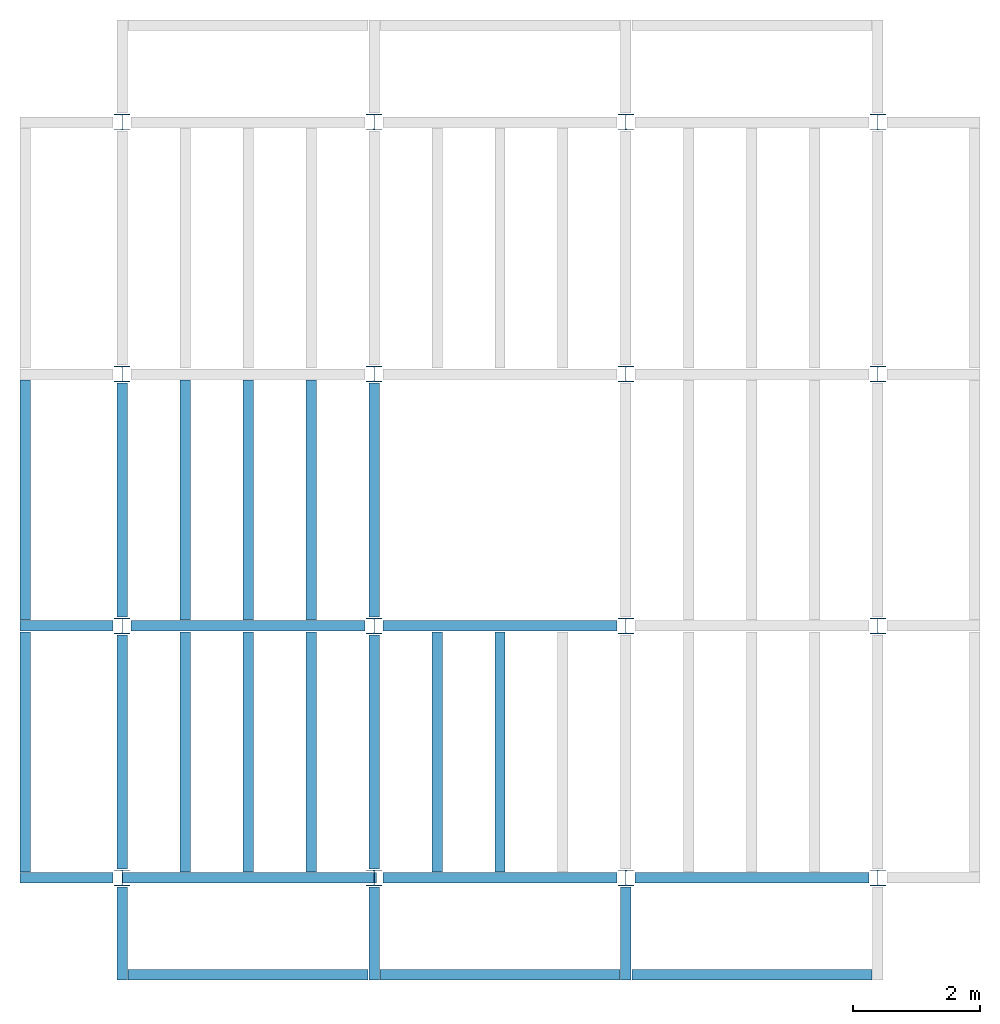
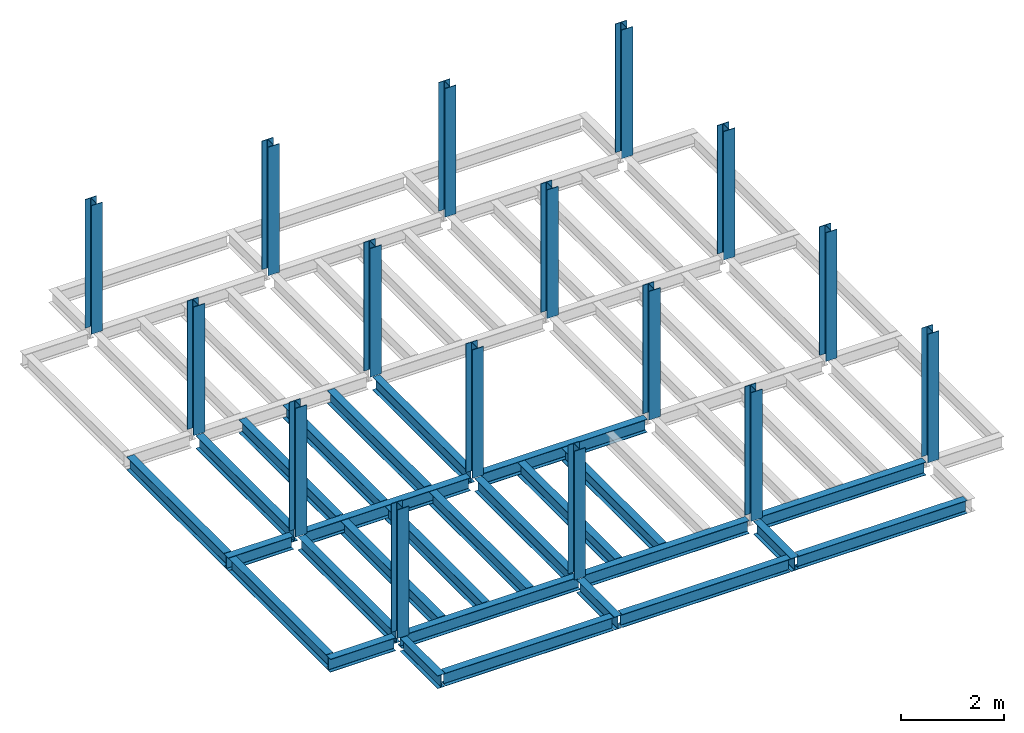
# One storey, part 1 of 3: 27 beams, 16 columns, 3 elements without a shape of their own.
"""IFC4 building model written with IfcOpenShell, lengths in feet."""

from ifc_helpers import new_model, entity, si_unit, converted_unit, derived_unit, direction, frame, origin, origin_2d, place, context, subcontext, project, spatial, line, arc, indexed_curve, i_section, outline, extrude, source, transform, mapped, material, type_object, type_shapes, element, aggregate, save


model = new_model("IFC4")

# Units and contexts
model_context = context("Model", 3, precision=0.0001, world=origin(), true_north=direction((6.123233995736766e-17, 1.0)))
plan_context = context("Plan", 3, precision=0.0001, world=origin(), true_north=direction((6.123233995736766e-17, 1.0)))
body_context = subcontext(model_context, "Body", "Model", "MODEL_VIEW")
ifc_project = project(units=[converted_unit("LENGTHUNIT", "FOOT", entity("IfcLengthMeasure", 0.3048), si_unit("LENGTHUNIT", "METRE"), dimensions=[1, 0, 0, 0, 0, 0, 0]), converted_unit("AREAUNIT", "SQUARE FOOT", entity("IfcAreaMeasure", 0.09290304), si_unit("AREAUNIT", "SQUARE_METRE"), dimensions=[2, 0, 0, 0, 0, 0, 0]), converted_unit("PLANEANGLEUNIT", "DEGREE", entity("IfcPlaneAngleMeasure", 0.017453292519943278), si_unit("PLANEANGLEUNIT", "RADIAN"), dimensions=[0, 0, 0, 0, 0, 0, 0]), converted_unit("VOLUMEUNIT", "CUBIC FOOT", entity("IfcVolumeMeasure", 0.028316846592000004), si_unit("VOLUMEUNIT", "CUBIC_METRE"), dimensions=[3, 0, 0, 0, 0, 0, 0]), si_unit("PRESSUREUNIT", "PASCAL"), derived_unit("MASSDENSITYUNIT", [(si_unit("MASSUNIT", "GRAM", prefix="KILO"), 1), (si_unit("LENGTHUNIT", "METRE"), -3)]), derived_unit("VAPORPERMEABILITYUNIT", [(si_unit("LENGTHUNIT", "METRE"), -1), (si_unit("TIMEUNIT", "SECOND"), 1)]), derived_unit("USERDEFINED", [(si_unit("MASSUNIT", "GRAM", prefix="KILO"), 1), (si_unit("LENGTHUNIT", "METRE"), 3), (si_unit("TIMEUNIT", "SECOND"), -3), (si_unit("ELECTRICCURRENTUNIT", "AMPERE"), -2)]), derived_unit("MODULUSOFELASTICITYUNIT", [(si_unit("MASSUNIT", "GRAM", prefix="KILO"), 1), (si_unit("LENGTHUNIT", "METRE"), -1), (si_unit("TIMEUNIT", "SECOND"), -2)]), derived_unit("THERMALEXPANSIONCOEFFICIENTUNIT", [(si_unit("THERMODYNAMICTEMPERATUREUNIT", "KELVIN"), -1)]), derived_unit("SPECIFICHEATCAPACITYUNIT", [(si_unit("TIMEUNIT", "SECOND"), -2), (si_unit("THERMODYNAMICTEMPERATUREUNIT", "KELVIN"), -1), (si_unit("LENGTHUNIT", "METRE"), 2)]), derived_unit("THERMALCONDUCTANCEUNIT", [(si_unit("MASSUNIT", "GRAM", prefix="KILO"), 1), (si_unit("TIMEUNIT", "SECOND"), -3), (si_unit("THERMODYNAMICTEMPERATUREUNIT", "KELVIN"), -1), (si_unit("LENGTHUNIT", "METRE"), 1)])], contexts=[model_context, plan_context])

# Site, building, storey
site_placement = place(None, origin())
site = spatial("IfcSite", under=ifc_project, at=site_placement, CompositionType="ELEMENT")
building_placement = place(site_placement, origin())
building = spatial("IfcBuilding", under=site, at=building_placement, CompositionType="ELEMENT")
storey_placement = place(building_placement, frame((0.0, 0.0, 59.875)))
storey = spatial("IfcBuildingStorey", under=building, at=storey_placement, Name="STR 07", CompositionType="ELEMENT", Elevation=59.875)

# Columns
ifc_material = material(Name="Steel ASTM A992", Category="Metal")
column_type = type_object("IfcColumnType", Name="W10X49", PredefinedType="COLUMN", material=ifc_material)
shared_shape_1 = source(origin(), body_context, "Body", "SweptSolid", [
    extrude(outline(indexed_curve([(-0.41666666666666663, -0.4166666666666676), (0.41666666666666663, -0.4166666666666676), (0.41666666666666663, -0.3699999999999996), (0.055833333333333846, -0.3699999999999996), (0.02637055078389421, -0.35779611588277277), (0.014166666666666636, -0.32833333333333287), (0.01416666666666665, 0.32833333333333303), (0.026370550783893467, 0.3577961158827727), (0.05583333333333332, 0.3700000000000003), (0.41666666666666663, 0.3700000000000003), (0.41666666666666663, 0.4166666666666656), (-0.41666666666666663, 0.4166666666666656), (-0.41666666666666663, 0.3700000000000003), (-0.05583333333333365, 0.3700000000000003), (-0.02637055078389416, 0.3577961158827734), (-0.014166666666666685, 0.32833333333333387), (-0.014166666666666685, -0.32833333333333264), (-0.026370550783893578, -0.3577961158827721), (-0.055833333333333374, -0.3699999999999996), (-0.41666666666666663, -0.3699999999999996)], segments=[line(1, 2, 3, 4), arc(4, 5, 6), line(6, 7), arc(7, 8, 9), line(9, 10, 11, 12, 13, 14), arc(14, 15, 16), line(16, 17), arc(17, 18, 19), line(19, 20, 1)], self_intersect=False)), frame((0.0, 0.0, 59.875), z_axis=(0.0, 0.0, 1.0), x_axis=(-1.0, 0.0, 0.0)), (0.0, 0.0, 1.0), 10.0),
])
type_shapes(column_type, [shared_shape_1])
for number, where, z_axis, x_axis, name in (
    (1, (0.0, 0.0, -59.875), (0.0, 0.0, 1.0), (-1.0, 0.0, 0.0), "W10X49"),
    (2, (0.0, 13.0, -59.875), (0.0, 0.0, 1.0), (-1.0, 0.0, 0.0), "W10X49"),
    (3, (0.0, 26.0, -59.875), (0.0, 0.0, 1.0), (-1.0, 0.0, 0.0), "W10X49"),
    (4, (0.0, 39.0, -59.875), (0.0, 0.0, 1.0), (-1.0, 0.0, 0.0), "W10X49"),
    (5, (13.0, 0.0, -59.875), (0.0, 0.0, 1.0), (-1.0, 0.0, 0.0), "W10X49"),
    (6, (13.0, 13.0, -59.875), (0.0, 0.0, 1.0), (-1.0, 0.0, 0.0), "W10X49"),
    (7, (13.0, 26.0, -59.875), (0.0, 0.0, 1.0), (-1.0, 0.0, 0.0), "W10X49"),
    (8, (13.0, 39.0, -59.875), (0.0, 0.0, 1.0), (-1.0, 0.0, 0.0), "W10X49"),
    (9, (26.0, 0.0, -59.875), (0.0, 0.0, 1.0), (-1.0, 0.0, 0.0), "W10X49"),
    (10, (26.0, 13.0, -59.875), (0.0, 0.0, 1.0), (-1.0, 0.0, 0.0), "W10X49"),
    (11, (26.0, 26.0, -59.875), (0.0, 0.0, 1.0), (-1.0, 0.0, 0.0), "W10X49"),
    (12, (26.0, 39.0, -59.875), (0.0, 0.0, 1.0), (-1.0, 0.0, 0.0), "W10X49"),
    (13, (39.0, 0.0, -59.875), (0.0, 0.0, 1.0), (-1.0, 0.0, 0.0), "W10X49"),
    (14, (39.0, 13.0, -59.875), (0.0, 0.0, 1.0), (-1.0, 0.0, 0.0), "W10X49"),
    (15, (39.0, 26.0, -59.875), (0.0, 0.0, 1.0), (-1.0, 0.0, 0.0), "W10X49"),
    (16, (39.0, 39.0, -59.875), (0.0, 0.0, 1.0), (-1.0, 0.0, 0.0), "W10X49"),
):
    element("IfcColumn", number, at=place(storey_placement, frame(where, z_axis=z_axis, x_axis=x_axis)), inside=storey, type_object=column_type, material=ifc_material, Name=name, ObjectType="W Shapes-Column:W10X49", PredefinedType="COLUMN", context=body_context, shape_type="MappedRepresentation", body=[
        mapped(shared_shape_1, transform((0.0, 0.0, 0.0), scale=1.0)),
    ])

# Beams
beam_type_1 = type_object("IfcBeamType", Name="W12X26", PredefinedType="JOIST", material=ifc_material)
shared_shape_2 = source(origin(), body_context, "Body", "SweptSolid", [
    extrude(outline(indexed_curve([(-0.27041666666666714, -0.47666666666666574), (-0.27041666666666714, -0.5083333333333351), (0.2704166666666669, -0.5083333333333351), (0.2704166666666669, -0.47666666666666574), (0.03458333333333309, -0.47666666666666574), (0.016905663803669493, -0.46934433619632937), (0.009583333333333202, -0.4516666666666659), (0.0095833333333332, 0.45166666666666705), (0.01690566380366948, 0.4693443361963307), (0.03458333333333325, 0.4766666666666671), (0.2704166666666669, 0.4766666666666671), (0.2704166666666669, 0.5083333333333312), (-0.2704166666666655, 0.5083333333333312), (-0.2704166666666655, 0.4766666666666671), (-0.034583333333333514, 0.47666666666666707), (-0.016905663803669865, 0.46934433619633054), (-0.009583333333333737, 0.45166666666666694), (-0.009583333333333735, -0.4516666666666658), (-0.01690566380367013, -0.4693443361963295), (-0.03458333333333368, -0.47666666666666574)], segments=[line(1, 2, 3, 4, 5), arc(5, 6, 7), line(7, 8), arc(8, 9, 10), line(10, 11, 12, 13, 14, 15), arc(15, 16, 17), line(17, 18), arc(18, 19, 20), line(20, 1)], self_intersect=False)), frame((-6.103346456692914, 0.0, 0.0), z_axis=(-1.0, 0.0, 0.0), x_axis=(0.0, -1.0, 0.0)), (0.0, 0.0, -1.0), 12.083333333333323),
])
type_shapes(beam_type_1, [shared_shape_2])
beam_1_placement = place(storey_placement, frame((6.561679790026266, 13.0, -0.5083333333333329)))
element("IfcBeam", 17, at=beam_1_placement, inside=storey, type_object=beam_type_1, material=ifc_material, Name="W12X26", ObjectType="W Shapes:W12X26", PredefinedType="JOIST", context=body_context, shape_type="MappedRepresentation", body=[
    mapped(shared_shape_2, transform((0.0, 0.0, 0.0), scale=1.0)),
])
for number, where, z_axis, x_axis, name in (
    (18, (0.0, 6.561679790026247, -0.5083333333333329), (0.0, 0.0, 1.0), (0.0, 1.0, 0.0), "W12X26"),
    (19, (13.0, 6.561679790026204, -0.5083333333333329), (0.0, 0.0, 1.0), (0.0, 1.0, 0.0), "W12X26"),
):
    element("IfcBeam", number, at=place(storey_placement, frame(where, z_axis=z_axis, x_axis=x_axis)), inside=storey, type_object=beam_type_1, material=ifc_material, Name=name, ObjectType="W Shapes:W12X26", PredefinedType="JOIST", context=body_context, shape_type="MappedRepresentation", body=[
        mapped(shared_shape_2, transform((0.0, 0.0, 0.0), scale=1.0)),
    ])
beam_type_2 = type_object("IfcBeamType", Name="W12X26", PredefinedType="JOIST", material=ifc_material)
shared_shape_3 = source(origin(), body_context, "Body", "SweptSolid", [
    extrude(outline(indexed_curve([(-0.27041666666666714, -0.47666666666666574), (-0.27041666666666714, -0.5083333333333351), (0.2704166666666669, -0.5083333333333351), (0.2704166666666669, -0.47666666666666574), (0.03458333333333309, -0.47666666666666574), (0.016905663803669493, -0.46934433619632937), (0.009583333333333202, -0.4516666666666659), (0.0095833333333332, 0.45166666666666705), (0.01690566380366948, 0.4693443361963307), (0.03458333333333325, 0.4766666666666671), (0.2704166666666669, 0.4766666666666671), (0.2704166666666669, 0.5083333333333312), (-0.2704166666666655, 0.5083333333333312), (-0.2704166666666655, 0.4766666666666671), (-0.034583333333333514, 0.47666666666666707), (-0.016905663803669865, 0.46934433619633054), (-0.009583333333333737, 0.45166666666666694), (-0.009583333333333735, -0.4516666666666658), (-0.01690566380367013, -0.4693443361963295), (-0.03458333333333368, -0.47666666666666574)], segments=[line(1, 2, 3, 4, 5), arc(5, 6, 7), line(7, 8), arc(8, 9, 10), line(10, 11, 12, 13, 14, 15), arc(15, 16, 17), line(17, 18), arc(18, 19, 20), line(20, 1)], self_intersect=False)), frame((-6.226706036745409, 0.0, 0.0), z_axis=(-1.0, 0.0, 0.0), x_axis=(0.0, -1.0, 0.0)), (0.0, 0.0, -1.0), 12.08333333333333),
])
type_shapes(beam_type_2, [shared_shape_3])
for number, where, name in (
    (20, (19.68503937007876, 13.0, -0.5083333333333329), "W12X26"),
    (21, (19.68503937007874, 0.0, -0.5083333333333329), "W12X26"),
):
    element("IfcBeam", number, at=place(storey_placement, frame(where)), inside=storey, type_object=beam_type_2, material=ifc_material, Name=name, ObjectType="W Shapes:W12X26", PredefinedType="JOIST", context=body_context, shape_type="MappedRepresentation", body=[
        mapped(shared_shape_3, transform((0.0, 0.0, 0.0), scale=1.0)),
    ])
for number, where, z_axis, x_axis, name in (
    (22, (0.0, 19.68503937007874, -0.5083333333333329), (0.0, 0.0, 1.0), (0.0, 1.0, 0.0), "W12X26"),
    (23, (13.0, 19.685039370078698, -0.5083333333333329), (0.0, 0.0, 1.0), (0.0, 1.0, 0.0), "W12X26"),
):
    element("IfcBeam", number, at=place(storey_placement, frame(where, z_axis=z_axis, x_axis=x_axis)), inside=storey, type_object=beam_type_2, material=ifc_material, Name=name, ObjectType="W Shapes:W12X26", PredefinedType="JOIST", context=body_context, shape_type="MappedRepresentation", body=[
        mapped(shared_shape_3, transform((0.0, 0.0, 0.0), scale=1.0)),
    ])

# Assembly, beams
assembly_1_placement = place(storey_placement, origin())
assembly_1 = element("IfcElementAssembly", 24, at=assembly_1_placement, inside=storey, Name="Structural Framing System", ObjectType="Structural Beam System:Structural Framing System", AssemblyPlace="NOTDEFINED", PredefinedType="BEAM_GRID")
beam_type_3 = type_object("IfcBeamType", Name="W12X26", PredefinedType="JOIST", material=ifc_material)
shared_shape_4 = source(origin(), body_context, "Body", "SweptSolid", [
    extrude(outline(indexed_curve([(-0.27041666666666714, -0.47666666666666574), (-0.27041666666666714, -0.5083333333333351), (0.2704166666666669, -0.5083333333333351), (0.2704166666666669, -0.47666666666666574), (0.03458333333333309, -0.47666666666666574), (0.016905663803669493, -0.46934433619632937), (0.009583333333333202, -0.4516666666666659), (0.0095833333333332, 0.45166666666666705), (0.01690566380366948, 0.4693443361963307), (0.03458333333333325, 0.4766666666666671), (0.2704166666666669, 0.4766666666666671), (0.2704166666666669, 0.5083333333333312), (-0.2704166666666655, 0.5083333333333312), (-0.2704166666666655, 0.4766666666666671), (-0.034583333333333514, 0.47666666666666707), (-0.016905663803669865, 0.46934433619633054), (-0.009583333333333737, 0.45166666666666694), (-0.009583333333333735, -0.4516666666666658), (-0.01690566380367013, -0.4693443361963295), (-0.03458333333333368, -0.47666666666666574)], segments=[line(1, 2, 3, 4, 5), arc(5, 6, 7), line(7, 8), arc(8, 9, 10), line(10, 11, 12, 13, 14, 15), arc(15, 16, 17), line(17, 18), arc(18, 19, 20), line(20, 1)], self_intersect=False)), frame((-6.187916666666566, 0.0, 0.0), z_axis=(-1.0, 0.0, 0.0), x_axis=(0.0, -1.0, 0.0)), (0.0, 0.0, -1.0), 12.375833333333075),
])
type_shapes(beam_type_3, [shared_shape_4])
beam_2_placement = place(assembly_1_placement, frame((3.250000000000031, 6.499999999999844, -0.5083333333333329), z_axis=(0.0, 0.0, 1.0), x_axis=(0.0, 1.0, 0.0)))
beam_2 = element("IfcBeam", 25, at=beam_2_placement, type_object=beam_type_3, material=ifc_material, Name="W12X26", ObjectType="W Shapes:W12X26", PredefinedType="JOIST", context=body_context, shape_type="MappedRepresentation", body=[
    mapped(shared_shape_4, transform((0.0, 0.0, 0.0), scale=1.0)),
])
beam_3_placement = place(assembly_1_placement, frame((6.5000000000000515, 6.4999999999998455, -0.5083333333333329), z_axis=(0.0, 0.0, 1.0), x_axis=(0.0, 1.0, 0.0)))
beam_3 = element("IfcBeam", 26, at=beam_3_placement, type_object=beam_type_3, material=ifc_material, Name="W12X26", ObjectType="W Shapes:W12X26", PredefinedType="JOIST", context=body_context, shape_type="MappedRepresentation", body=[
    mapped(shared_shape_4, transform((0.0, 0.0, 0.0), scale=1.0)),
])
beam_4_placement = place(assembly_1_placement, frame((9.750000000000073, 6.499999999999844, -0.5083333333333329), z_axis=(0.0, 0.0, 1.0), x_axis=(0.0, 1.0, 0.0)))
beam_4 = element("IfcBeam", 27, at=beam_4_placement, type_object=beam_type_3, material=ifc_material, Name="W12X26", ObjectType="W Shapes:W12X26", PredefinedType="JOIST", context=body_context, shape_type="MappedRepresentation", body=[
    mapped(shared_shape_4, transform((0.0, 0.0, 0.0), scale=1.0)),
])
aggregate(assembly_1, [beam_2, beam_3, beam_4])

assembly_2_placement = place(storey_placement, origin())
assembly_2 = element("IfcElementAssembly", 28, at=assembly_2_placement, inside=storey, Name="Structural Framing System", ObjectType="Structural Beam System:Structural Framing System", AssemblyPlace="NOTDEFINED", PredefinedType="BEAM_GRID")
beam_5_placement = place(assembly_2_placement, frame((3.2500000000000515, 19.49999999999968, -0.5083333333333329), z_axis=(0.0, 0.0, 1.0), x_axis=(0.0, 1.0, 0.0)))
beam_5 = element("IfcBeam", 29, at=beam_5_placement, type_object=beam_type_3, material=ifc_material, Name="W12X26", ObjectType="W Shapes:W12X26", PredefinedType="JOIST", context=body_context, shape_type="MappedRepresentation", body=[
    mapped(shared_shape_4, transform((0.0, 0.0, 0.0), scale=1.0)),
])
beam_6_placement = place(assembly_2_placement, frame((6.500000000000073, 19.499999999999666, -0.5083333333333329), z_axis=(0.0, 0.0, 1.0), x_axis=(0.0, 1.0, 0.0)))
beam_6 = element("IfcBeam", 30, at=beam_6_placement, type_object=beam_type_3, material=ifc_material, Name="W12X26", ObjectType="W Shapes:W12X26", PredefinedType="JOIST", context=body_context, shape_type="MappedRepresentation", body=[
    mapped(shared_shape_4, transform((0.0, 0.0, 0.0), scale=1.0)),
])
beam_7_placement = place(assembly_2_placement, frame((9.750000000000094, 19.49999999999966, -0.5083333333333329), z_axis=(0.0, 0.0, 1.0), x_axis=(0.0, 1.0, 0.0)))
beam_7 = element("IfcBeam", 31, at=beam_7_placement, type_object=beam_type_3, material=ifc_material, Name="W12X26", ObjectType="W Shapes:W12X26", PredefinedType="JOIST", context=body_context, shape_type="MappedRepresentation", body=[
    mapped(shared_shape_4, transform((0.0, 0.0, 0.0), scale=1.0)),
])
aggregate(assembly_2, [beam_5, beam_6, beam_7])

assembly_3_placement = place(storey_placement, origin())
assembly_3 = element("IfcElementAssembly", 32, at=assembly_3_placement, inside=storey, Name="Structural Framing System", ObjectType="Structural Beam System:Structural Framing System", AssemblyPlace="NOTDEFINED", PredefinedType="BEAM_GRID")
beam_8_placement = place(assembly_3_placement, frame((16.25000000000009, 6.499999999999801, -0.5083333333333329), z_axis=(0.0, 0.0, 1.0), x_axis=(0.0, 1.0, 0.0)))
beam_8 = element("IfcBeam", 33, at=beam_8_placement, type_object=beam_type_3, material=ifc_material, Name="W12X26", ObjectType="W Shapes:W12X26", PredefinedType="JOIST", context=body_context, shape_type="MappedRepresentation", body=[
    mapped(shared_shape_4, transform((0.0, 0.0, 0.0), scale=1.0)),
])
beam_9_placement = place(assembly_3_placement, frame((19.500000000000096, 6.499999999999801, -0.5083333333333329), z_axis=(0.0, 0.0, 1.0), x_axis=(0.0, 1.0, 0.0)))
beam_9 = element("IfcBeam", 34, at=beam_9_placement, type_object=beam_type_3, material=ifc_material, Name="W12X26", ObjectType="W Shapes:W12X26", PredefinedType="JOIST", context=body_context, shape_type="MappedRepresentation", body=[
    mapped(shared_shape_4, transform((0.0, 0.0, 0.0), scale=1.0)),
])
aggregate(assembly_3, [beam_8, beam_9])

# Beams
for number, where, z_axis, x_axis, name in (
    (35, (-5.0, 6.499999999999858, -0.5083333333333329), (0.0, 0.0, 1.0), (0.0, -1.0, 0.0), "W12X26"),
    (36, (-5.0, 19.499999999999705, -0.5083333333333329), (0.0, 0.0, 1.0), (0.0, 1.0, 0.0), "W12X26"),
):
    element("IfcBeam", number, at=place(storey_placement, frame(where, z_axis=z_axis, x_axis=x_axis)), inside=storey, type_object=beam_type_3, material=ifc_material, Name=name, ObjectType="W Shapes:W12X26", PredefinedType="JOIST", context=body_context, shape_type="MappedRepresentation", body=[
        mapped(shared_shape_4, transform((0.0, 0.0, 0.0), scale=1.0)),
    ])
beam_type_4 = type_object("IfcBeamType", Name="W12X26", PredefinedType="JOIST", material=ifc_material)
shared_shape_5 = source(origin(), body_context, "Body", "SweptSolid", [
    extrude(outline(indexed_curve([(-0.27041666666666714, -0.47666666666666574), (-0.27041666666666714, -0.5083333333333351), (0.2704166666666669, -0.5083333333333351), (0.2704166666666669, -0.47666666666666574), (0.03458333333333309, -0.47666666666666574), (0.016905663803669493, -0.46934433619632937), (0.009583333333333202, -0.4516666666666659), (0.0095833333333332, 0.45166666666666705), (0.01690566380366948, 0.4693443361963307), (0.03458333333333325, 0.4766666666666671), (0.2704166666666669, 0.4766666666666671), (0.2704166666666669, 0.5083333333333312), (-0.2704166666666655, 0.5083333333333312), (-0.2704166666666655, 0.4766666666666671), (-0.034583333333333514, 0.47666666666666707), (-0.016905663803669865, 0.46934433619633054), (-0.009583333333333737, 0.45166666666666694), (-0.009583333333333735, -0.4516666666666658), (-0.01690566380367013, -0.4693443361963295), (-0.03458333333333368, -0.47666666666666574)], segments=[line(1, 2, 3, 4, 5), arc(5, 6, 7), line(7, 8), arc(8, 9, 10), line(10, 11, 12, 13, 14, 15), arc(15, 16, 17), line(17, 18), arc(18, 19, 20), line(20, 1)], self_intersect=False)), frame((-6.165026246719308, 0.0, 0.0), z_axis=(-1.0, 0.0, 0.0), x_axis=(0.0, -1.0, 0.0)), (0.0, 0.0, -1.0), 12.08333333333334),
])
type_shapes(beam_type_4, [shared_shape_5])
beam_10_placement = place(storey_placement, frame((32.623359580052536, 0.0, -0.5083333333333329)))
element("IfcBeam", 37, at=beam_10_placement, inside=storey, type_object=beam_type_4, material=ifc_material, Name="W12X26", ObjectType="W Shapes:W12X26", PredefinedType="JOIST", context=body_context, shape_type="MappedRepresentation", body=[
    mapped(shared_shape_5, transform((0.0, 0.0, 0.0), scale=1.0)),
])
beam_type_5 = type_object("IfcBeamType", Name="W12X26", PredefinedType="JOIST", material=ifc_material)
shared_shape_6 = source(origin(), body_context, "Body", "SweptSolid", [
    extrude(outline(indexed_curve([(0.47666666666666574, -0.2704166666666672), (0.5083333333333351, -0.2704166666666672), (0.5083333333333351, 0.27041666666666686), (0.47666666666666574, 0.27041666666666686), (0.47666666666666574, 0.03458333333333307), (0.46934433619632937, 0.016905663803669473), (0.4516666666666659, 0.00958333333333318), (-0.45166666666666705, 0.00958333333333318), (-0.4693443361963307, 0.01690566380366946), (-0.4766666666666671, 0.03458333333333323), (-0.4766666666666671, 0.27041666666666686), (-0.5083333333333312, 0.27041666666666686), (-0.5083333333333312, -0.27041666666666553), (-0.4766666666666671, -0.27041666666666553), (-0.47666666666666707, -0.034583333333333535), (-0.46934433619633054, -0.016905663803669885), (-0.45166666666666694, -0.00958333333333376), (0.4516666666666658, -0.009583333333333756), (0.4693443361963295, -0.01690566380367015), (0.47666666666666574, -0.0345833333333337)], segments=[line(1, 2, 3, 4, 5), arc(5, 6, 7), line(7, 8), arc(8, 9, 10), line(10, 11, 12, 13, 14, 15), arc(15, 16, 17), line(17, 18), arc(18, 19, 20), line(20, 1)], self_intersect=False)), frame((-2.0416666666666208, 0.0, 0.0), z_axis=(1.0, 0.0, 0.0), x_axis=(0.0, 0.0, -1.0)), (0.0, 0.0, 1.0), 4.812083333333336),
])
type_shapes(beam_type_5, [shared_shape_6])
for number, where, z_axis, x_axis, name in (
    (38, (26.0, -2.500000000000538, -0.5083333333333329), (0.0, 0.0, 1.0), (0.0, -1.0, 0.0), "W12X26"),
    (39, (-2.499999999999853, 13.0, -0.5083333333333329), (0.0, 0.0, 1.0), (-1.0, 0.0, 0.0), "W12X26"),
    (40, (-2.4999999999998743, 0.0, -0.5083333333333329), (0.0, 0.0, 1.0), (-1.0, 0.0, 0.0), "W12X26"),
):
    element("IfcBeam", number, at=place(storey_placement, frame(where, z_axis=z_axis, x_axis=x_axis)), inside=storey, type_object=beam_type_5, material=ifc_material, Name=name, ObjectType="W Shapes:W12X26", PredefinedType="JOIST", context=body_context, shape_type="MappedRepresentation", body=[
        mapped(shared_shape_6, transform((0.0, 0.0, 0.0), scale=1.0)),
    ])
beam_type_6 = type_object("IfcBeamType", Name="W12X26", PredefinedType="JOIST", material=ifc_material)
shared_shape_7 = source(origin(), body_context, "Body", "SweptSolid", [
    extrude(outline(indexed_curve([(-0.27041666666666686, -0.5083333333333329), (0.27041666666666553, -0.5083333333333329), (0.27041666666666553, -0.47666666666666657), (0.03458333333333355, -0.47666666666666657), (0.016905663803669983, -0.469344336196329), (0.009583333333333726, -0.451666666666668), (0.009583333333333735, 0.451666666666668), (0.01690566380367013, 0.469344336196329), (0.034583333333333716, 0.47666666666666657), (0.2704166666666672, 0.4766666666666737), (0.2704166666666672, 0.50833333333334), (-0.27041666666666686, 0.5083333333333329), (-0.27041666666666686, 0.47666666666666657), (-0.03458333333333308, 0.47666666666666657), (-0.016905663803669462, 0.469344336196329), (-0.00958333333333316, 0.451666666666668), (-0.009583333333333194, -0.451666666666668), (-0.0169056638036695, -0.469344336196329), (-0.03458333333333319, -0.47666666666666657), (-0.27041666666666686, -0.47666666666666657)], segments=[line(1, 2, 3, 4), arc(4, 5, 6), line(6, 7), arc(7, 8, 9), line(9, 10, 11, 12, 13, 14), arc(14, 15, 16), line(16, 17), arc(17, 18, 19), line(19, 20, 1)], self_intersect=False)), frame((0.0, -0.45833333333383364, 59.36666666666665), z_axis=(0.0, -1.0, 0.0), x_axis=(-1.0, 0.0, 0.0)), (0.0, 0.0, 1.0), 4.812083333333337),
])
type_shapes(beam_type_6, [shared_shape_7])
beam_11_placement = place(storey_placement, frame((0.0, 0.0, -59.875)))
element("IfcBeam", 41, at=beam_11_placement, inside=storey, type_object=beam_type_6, material=ifc_material, Name="W12X26", ObjectType="W Shapes:W12X26", PredefinedType="JOIST", context=body_context, shape_type="MappedRepresentation", body=[
    mapped(shared_shape_7, transform((0.0, 0.0, 0.0), scale=1.0)),
])
beam_type_7 = type_object("IfcBeamType", Name="W12X26", PredefinedType="JOIST", material=ifc_material)
shared_shape_8 = source(origin(), body_context, "Body", "SweptSolid", [
    extrude(outline(indexed_curve([(-0.2704166666666641, -0.5083333333333329), (0.27041666666666764, -0.5083333333333329), (0.27041666666666764, -0.47666666666666657), (0.03458333333333563, -0.47666666666666657), (0.016905663803672866, -0.469344336196329), (0.009583333333335275, -0.451666666666668), (0.009583333333335275, 0.451666666666668), (0.01690566380367109, 0.469344336196329), (0.03458333333333563, 0.47666666666666657), (0.2704166666666694, 0.4766666666666737), (0.27041666666666764, 0.50833333333334), (-0.27041666666666586, 0.5083333333333329), (-0.27041666666666586, 0.47666666666666657), (-0.03458333333333208, 0.47666666666666657), (-0.016905663803667537, 0.469344336196329), (-0.009583333333331723, 0.451666666666668), (-0.009583333333331723, -0.451666666666668), (-0.016905663803667537, -0.469344336196329), (-0.03458333333333208, -0.47666666666666657), (-0.27041666666666586, -0.47666666666666657)], segments=[line(1, 2, 3, 4), arc(4, 5, 6), line(6, 7), arc(7, 8, 9), line(9, 10, 11, 12, 13, 14), arc(14, 15, 16), line(16, 17), arc(17, 18, 19), line(19, 20, 1)], self_intersect=False)), frame((13.0, -0.45833333333387627, 59.36666666666665), z_axis=(0.0, -1.0, 0.0), x_axis=(-1.0, 0.0, 0.0)), (0.0, 0.0, 1.0), 4.812083333333337),
])
type_shapes(beam_type_7, [shared_shape_8])
beam_12_placement = place(storey_placement, frame((0.0, 0.0, -59.875)))
element("IfcBeam", 42, at=beam_12_placement, inside=storey, type_object=beam_type_7, material=ifc_material, Name="W12X26", ObjectType="W Shapes:W12X26", PredefinedType="JOIST", context=body_context, shape_type="MappedRepresentation", body=[
    mapped(shared_shape_8, transform((0.0, 0.0, 0.0), scale=1.0)),
])
beam_type_8 = type_object("IfcBeamType", Name="W12X26", PredefinedType="JOIST", material=ifc_material)
shared_shape_9 = source(origin(), body_context, "Body", "SweptSolid", [
    extrude(outline(indexed_curve([(0.47666666666666574, -0.2704166666666672), (0.5083333333333351, -0.2704166666666672), (0.5083333333333351, 0.27041666666666686), (0.47666666666666574, 0.27041666666666686), (0.47666666666666574, 0.03458333333333307), (0.46934433619632937, 0.016905663803669473), (0.4516666666666659, 0.00958333333333318), (-0.45166666666666705, 0.00958333333333318), (-0.4693443361963307, 0.01690566380366946), (-0.4766666666666671, 0.03458333333333323), (-0.4766666666666671, 0.27041666666666686), (-0.5083333333333312, 0.27041666666666686), (-0.5083333333333312, -0.27041666666666553), (-0.4766666666666671, -0.27041666666666553), (-0.47666666666666707, -0.034583333333333535), (-0.46934433619633054, -0.016905663803669885), (-0.45166666666666694, -0.00958333333333376), (0.4516666666666658, -0.009583333333333756), (0.4693443361963295, -0.01690566380367015), (0.47666666666666574, -0.0345833333333337)], segments=[line(1, 2, 3, 4, 5), arc(5, 6, 7), line(7, 8), arc(8, 9, 10), line(10, 11, 12, 13, 14, 15), arc(15, 16, 17), line(17, 18), arc(18, 19, 20), line(20, 1)], self_intersect=False)), frame((-6.187916666666685, 0.0, 0.0), z_axis=(1.0, 0.0, 0.0), x_axis=(0.0, 0.0, -1.0)), (0.0, 0.0, 1.0), 12.375833333333318),
])
type_shapes(beam_type_8, [shared_shape_9])
beam_13_placement = place(storey_placement, frame((32.50000000000002, -5.0, -0.5083333333333329)))
element("IfcBeam", 43, at=beam_13_placement, inside=storey, type_object=beam_type_8, material=ifc_material, Name="W Shapes:W12X26", ObjectType="W Shapes:W12X26", PredefinedType="JOIST", context=body_context, shape_type="MappedRepresentation", body=[
    mapped(shared_shape_9, transform((0.0, 0.0, 0.0), scale=1.0)),
])
beam_type_9 = type_object("IfcBeamType", Name="W12X26", PredefinedType="JOIST", material=ifc_material)
shared_shape_10 = source(origin(), body_context, "Body", "SweptSolid", [
    extrude(outline(indexed_curve([(-0.5083333333333329, -0.270416666666665), (-0.47666666666666657, -0.270416666666665), (-0.47666666666666657, -0.034583333333333854), (-0.469344336196329, -0.0169056638036702), (-0.451666666666668, -0.009583333333333499), (0.451666666666668, -0.009583333333332611), (0.469344336196329, -0.016905663803669313), (0.47666666666666657, -0.034583333333332966), (0.4766666666666737, -0.27041666666666675), (0.50833333333334, -0.27041666666666675), (0.5083333333333329, 0.27041666666666675), (0.47666666666666657, 0.27041666666666764), (0.47666666666666657, 0.034583333333333854), (0.469344336196329, 0.0169056638036702), (0.451666666666668, 0.009583333333333499), (-0.451666666666668, 0.009583333333333499), (-0.469344336196329, 0.016905663803669313), (-0.47666666666666657, 0.034583333333332966), (-0.47666666666666657, 0.27041666666666675), (-0.5083333333333329, 0.27041666666666764)], segments=[line(1, 2, 3), arc(3, 4, 5), line(5, 6), arc(6, 7, 8), line(8, 9, 10, 11, 12, 13), arc(13, 14, 15), line(15, 16), arc(16, 17, 18), line(18, 19, 20, 1)], self_intersect=False)), frame((0.3120833333333186, -5.0, 59.36666666666665), z_axis=(1.0, 0.0, 0.0), x_axis=(0.0, 0.0, -1.0)), (0.0, 0.0, 1.0), 12.37583333333332),
])
type_shapes(beam_type_9, [shared_shape_10])
beam_14_placement = place(storey_placement, frame((0.0, 0.0, -59.875)))
element("IfcBeam", 44, at=beam_14_placement, inside=storey, type_object=beam_type_9, material=ifc_material, Name="W Shapes:W12X26", ObjectType="W Shapes:W12X26", PredefinedType="JOIST", context=body_context, shape_type="MappedRepresentation", body=[
    mapped(shared_shape_10, transform((0.0, 0.0, 0.0), scale=1.0)),
])
beam_type_10 = type_object("IfcBeamType", Name="W12X26", PredefinedType="JOIST", material=ifc_material)
shared_shape_11 = source(origin(), body_context, "Body", "SweptSolid", [
    extrude(outline(indexed_curve([(-0.5083333333333253, -0.2704166666666819), (-0.47666666666665897, -0.270416666666681), (-0.47666666666666563, -0.034583333333347226), (-0.4693443361963285, -0.016905663803682476), (-0.4516666666666677, -0.009583333333346168), (0.45166666666666827, -0.00958333333332083), (0.4693443361963295, -0.016905663803657038), (0.4766666666666675, -0.03458333333332048), (0.4766666666666742, -0.27041666666665426), (0.5083333333333475, -0.27041666666665337), (0.5083333333333324, 0.270416666666681), (0.47666666666665897, 0.2704166666666801), (0.47666666666666563, 0.034583333333347226), (0.4693443361963285, 0.016905663803682476), (0.4516666666666677, 0.009583333333346168), (-0.45166666666666827, 0.00958333333332083), (-0.4693443361963295, 0.016905663803657038), (-0.4766666666666675, 0.03458333333332048), (-0.4766666666666742, 0.2704166666666516), (-0.5083333333333404, 0.2704166666666507)], segments=[line(1, 2, 3), arc(3, 4, 5), line(5, 6), arc(6, 7, 8), line(8, 9, 10, 11, 12, 13), arc(13, 14, 15), line(15, 16), arc(16, 17, 18), line(18, 19, 20, 1)], self_intersect=False)), frame((25.68791666666654, -5.0, 59.36666666666665), z_axis=(-1.0, 0.0, 0.0), x_axis=(0.0, 0.0, -1.0)), (0.0, 0.0, 1.0), 12.375833333333075),
])
type_shapes(beam_type_10, [shared_shape_11])
beam_15_placement = place(storey_placement, frame((0.0, 0.0, -59.875)))
element("IfcBeam", 45, at=beam_15_placement, inside=storey, type_object=beam_type_10, material=ifc_material, Name="W Shapes:W12X26", ObjectType="W Shapes:W12X26", PredefinedType="JOIST", context=body_context, shape_type="MappedRepresentation", body=[
    mapped(shared_shape_11, transform((0.0, 0.0, 0.0), scale=1.0)),
])
beam_type_11 = type_object("IfcBeamType", Name="W12X26", PredefinedType="BEAM")
beam_16_placement = place(storey_placement, frame((0.0, 0.0, -0.50833333333334), z_axis=(-1.0, 0.0, 0.0), x_axis=(0.0, -1.0, 0.0)))
element("IfcBeam", 46, at=beam_16_placement, inside=storey, type_object=beam_type_11, material=ifc_material, Name="W12X26", ObjectType="W12X26", context=model_context, shape_type="SweptSolid", body=[
    extrude(i_section(OverallWidth=0.5408333333333333, OverallDepth=1.0166666666666666, WebThickness=0.019166666666666665, FlangeThickness=0.03166666666666666, FilletRadius=0.024999999999999998, at=origin_2d()), origin(), (0.0, 0.0, -1.0), 13.123359580052494),
])

save(model, "model.ifc")
